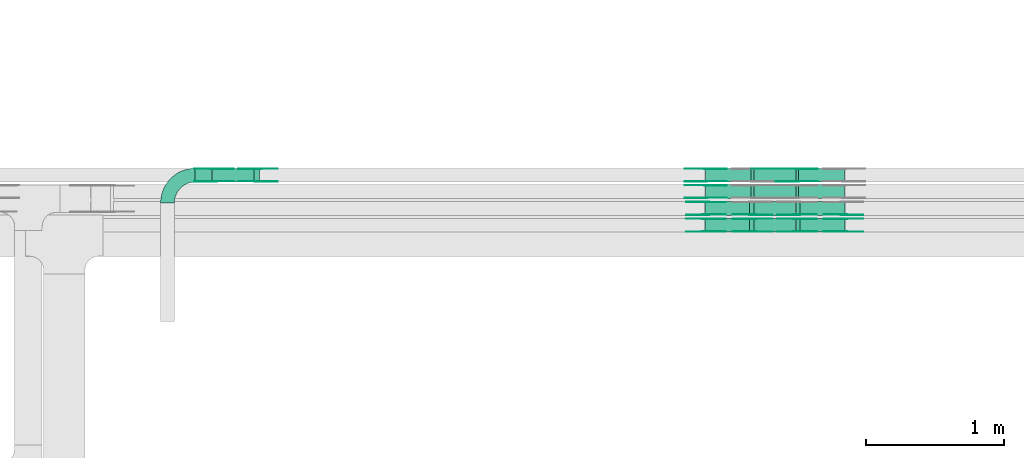
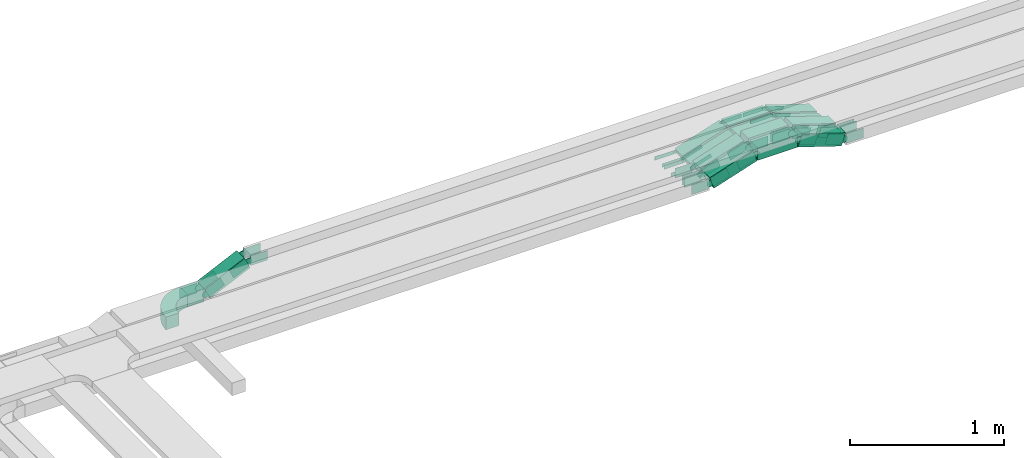
# One storey, part 8 of 19: 48 flow fittings, 14 flow segments.
"""IFC2X3 building model written with IfcOpenShell, lengths in millimetres."""

from ifc_helpers import new_model, entity, si_unit, converted_unit, derived_unit, direction, frame, frame_2d, origin, origin_2d_with_axis, place, context, subcontext, project, spatial, polyline, circle_curve, parameter, trimmed, segment, composite_curve, rectangle, outline, extrude, source, transform, mapped, material, type_object, type_shapes, element, save


model = new_model("IFC2X3")

# Units and contexts
model_context = context("Model", 3, precision=0.01, world=origin(), true_north=direction((6.12303176911189e-17, 1.0)))
body_context = subcontext(model_context, "Body", "Model", "MODEL_VIEW")
ifc_project = project(units=[si_unit("LENGTHUNIT", "METRE", prefix="MILLI"), si_unit("AREAUNIT", "SQUARE_METRE"), si_unit("VOLUMEUNIT", "CUBIC_METRE"), converted_unit("PLANEANGLEUNIT", "DEGREE", entity("IfcRatioMeasure", 0.0174532925199433), si_unit("PLANEANGLEUNIT", "RADIAN"), dimensions=[0, 0, 0, 0, 0, 0, 0]), si_unit("MASSUNIT", "GRAM", prefix="KILO"), derived_unit("MASSDENSITYUNIT", [(si_unit("MASSUNIT", "GRAM", prefix="KILO"), 1), (si_unit("LENGTHUNIT", "METRE"), -3)]), derived_unit("MOMENTOFINERTIAUNIT", [(si_unit("LENGTHUNIT", "METRE"), 4)]), si_unit("TIMEUNIT", "SECOND"), si_unit("FREQUENCYUNIT", "HERTZ"), si_unit("THERMODYNAMICTEMPERATUREUNIT", "DEGREE_CELSIUS"), derived_unit("THERMALTRANSMITTANCEUNIT", [(si_unit("MASSUNIT", "GRAM", prefix="KILO"), 1), (si_unit("THERMODYNAMICTEMPERATUREUNIT", "KELVIN"), -1), (si_unit("TIMEUNIT", "SECOND"), -3)]), derived_unit("VOLUMETRICFLOWRATEUNIT", [(si_unit("LENGTHUNIT", "METRE"), 3), (si_unit("TIMEUNIT", "SECOND"), -1)]), derived_unit("MASSFLOWRATEUNIT", [(si_unit("MASSUNIT", "GRAM", prefix="KILO"), 1), (si_unit("TIMEUNIT", "SECOND"), -1)]), derived_unit("ROTATIONALFREQUENCYUNIT", [(si_unit("TIMEUNIT", "SECOND"), -1)]), si_unit("ELECTRICCURRENTUNIT", "AMPERE"), si_unit("ELECTRICVOLTAGEUNIT", "VOLT"), si_unit("POWERUNIT", "WATT"), si_unit("FORCEUNIT", "NEWTON", prefix="KILO"), si_unit("ILLUMINANCEUNIT", "LUX"), si_unit("LUMINOUSFLUXUNIT", "LUMEN"), si_unit("LUMINOUSINTENSITYUNIT", "CANDELA"), derived_unit("USERDEFINED", [(si_unit("MASSUNIT", "GRAM", prefix="KILO"), -1), (si_unit("LENGTHUNIT", "METRE"), -2), (si_unit("TIMEUNIT", "SECOND"), 3), (si_unit("LUMINOUSFLUXUNIT", "LUMEN"), 1)]), derived_unit("LINEARVELOCITYUNIT", [(si_unit("LENGTHUNIT", "METRE"), 1), (si_unit("TIMEUNIT", "SECOND"), -1)]), si_unit("PRESSUREUNIT", "PASCAL"), derived_unit("USERDEFINED", [(si_unit("LENGTHUNIT", "METRE"), -2), (si_unit("MASSUNIT", "GRAM", prefix="KILO"), 1), (si_unit("TIMEUNIT", "SECOND"), -2)]), derived_unit("LINEARFORCEUNIT", [(si_unit("MASSUNIT", "GRAM", prefix="KILO"), 1), (si_unit("LENGTHUNIT", "METRE"), 1), (si_unit("TIMEUNIT", "SECOND"), -2), (si_unit("LENGTHUNIT", "METRE"), -1)]), derived_unit("PLANARFORCEUNIT", [(si_unit("MASSUNIT", "GRAM", prefix="KILO"), 1), (si_unit("LENGTHUNIT", "METRE"), 1), (si_unit("TIMEUNIT", "SECOND"), -2), (si_unit("LENGTHUNIT", "METRE"), -2)])], contexts=[model_context])

# Site, building, storey
site_placement = place(None, frame((0.0, -0.00077364408347762, 0.0)))
site = spatial("IfcSite", under=ifc_project, at=site_placement, CompositionType="ELEMENT")
building_placement = place(site_placement, origin())
building = spatial("IfcBuilding", under=site, at=building_placement, CompositionType="ELEMENT")
storey_placement = place(building_placement, frame((0.0, 0.0, 12000.0)))
storey = spatial("IfcBuildingStorey", under=building, at=storey_placement, CompositionType="ELEMENT", Elevation=12000.0)

# Flow segments
cable_carrier_segment_type = type_object("IfcCableCarrierSegmentType", PredefinedType="CABLETRAYSEGMENT")
flow_segment_1_placement = place(storey_placement, frame((19454.0361878455, 14792.4967897, 2660.16660841013)))
element("IfcFlowSegment", 1, at=flow_segment_1_placement, inside=storey, type_object=cable_carrier_segment_type, context=body_context, shape_type="SweptSolid", body=[
    extrude(rectangle(XDim=100.000000000002, YDim=99.9999999999989, at=origin_2d_with_axis()), frame((21.1309130872599, 50.0, 45.315389351734), z_axis=(0.906307787034617, 0.0, 0.422618261745059), x_axis=(-0.422618261745059, 0.0, 0.906307787034617)), (0.0, 0.0, 1.0), 328.987213903568),
])
flow_segment_2_placement = place(storey_placement, frame((19327.5152668448, 14792.4967897, 2650.0)))
element("IfcFlowSegment", 2, at=flow_segment_2_placement, inside=storey, type_object=cable_carrier_segment_type, context=body_context, shape_type="SweptSolid", body=[
    extrude(rectangle(XDim=122.924140166767, YDim=99.9999999999989, at=frame_2d((-1.08357767203415e-12, 0.0), x_axis=(1.0, 0.0))), frame((61.4620700833843, 50.0, 0.0), z_axis=(0.0, 0.0, 1.0), x_axis=(-1.0, 0.0, 0.0)), (0.0, 0.0, 1.0), 99.9999999999989),
])
flow_segment_3_placement = place(storey_placement, frame((23686.3473335923, 14792.4967897, 2502.95196511442)))
element("IfcFlowSegment", 3, at=flow_segment_3_placement, inside=storey, type_object=cable_carrier_segment_type, context=body_context, shape_type="SweptSolid", body=[
    extrude(rectangle(XDim=50.0000000000005, YDim=99.9999999999989, at=origin_2d_with_axis()), frame((7.72542485937545, 50.0, 131.565774838742), z_axis=(0.951056516295132, 0.0, -0.309016994375015), x_axis=(0.309016994375015, 0.0, 0.951056516295132)), (0.0, 0.0, 1.0), 348.813702461178),
])
flow_segment_4_placement = place(storey_placement, frame((23376.396793967, 14792.4967897, 2611.24611797497)))
element("IfcFlowSegment", 4, at=flow_segment_4_placement, inside=storey, type_object=cable_carrier_segment_type, context=body_context, shape_type="SweptSolid", body=[
    extrude(rectangle(XDim=306.763415131531, YDim=99.9999999999989, at=origin_2d_with_axis()), frame((153.381707565766, 50.0, 0.0), z_axis=(0.0, 0.0, 1.0), x_axis=(-1.0, 0.0, 0.0)), (0.0, 0.0, 1.0), 50.0000000000016),
])
flow_segment_5_placement = place(storey_placement, frame((23026.0172750557, 14792.4967897, 2502.95196511442)))
element("IfcFlowSegment", 5, at=flow_segment_5_placement, inside=storey, type_object=cable_carrier_segment_type, context=body_context, shape_type="SweptSolid", body=[
    extrude(rectangle(XDim=49.9999999999991, YDim=99.9999999999989, at=frame_2d((0.0, 6.69686528453894e-13), x_axis=(0.0, 1.0))), frame((7.72542485937978, 50.0, 23.7764129073785), z_axis=(0.951056516295132, 0.0, 0.309016994375015), x_axis=(0.0, 1.0, 0.0)), (0.0, 0.0, 1.0), 348.813702461196),
])
flow_segment_6_placement = place(storey_placement, frame((23686.3473335923, 14673.6298749259, 2502.95196511437)))
element("IfcFlowSegment", 6, at=flow_segment_6_placement, inside=storey, type_object=cable_carrier_segment_type, context=body_context, shape_type="SweptSolid", body=[
    extrude(rectangle(XDim=50.0000000000005, YDim=99.9999999999989, at=frame_2d((0.0, -2.16715534406831e-12), x_axis=(1.0, 0.0))), frame((7.72542485937545, 50.0, 131.565774838805), z_axis=(0.951056516295132, 0.0, -0.309016994375015), x_axis=(0.309016994375015, 0.0, 0.951056516295132)), (0.0, 0.0, 1.0), 348.813702461366),
])
flow_segment_7_placement = place(storey_placement, frame((23376.396793967, 14673.6298749258, 2611.24611797498)))
element("IfcFlowSegment", 7, at=flow_segment_7_placement, inside=storey, type_object=cable_carrier_segment_type, context=body_context, shape_type="SweptSolid", body=[
    extrude(rectangle(XDim=306.763415131523, YDim=99.9999999999989, at=frame_2d((0.0, -2.16715534406831e-12), x_axis=(1.0, 0.0))), frame((153.381707565761, 50.0, 0.0), z_axis=(0.0, 0.0, 1.0), x_axis=(-1.0, 0.0, 0.0)), (0.0, 0.0, 1.0), 50.0000000000016),
])
flow_segment_8_placement = place(storey_placement, frame((23026.0172750555, 14673.6298749258, 2502.95196511436)))
element("IfcFlowSegment", 8, at=flow_segment_8_placement, inside=storey, type_object=cable_carrier_segment_type, context=body_context, shape_type="SweptSolid", body=[
    extrude(rectangle(XDim=50.0000000000005, YDim=99.9999999999989, at=frame_2d((-2.16715534406831e-12, 0.0), x_axis=(0.0, 1.0))), frame((7.72542485937545, 50.0, 23.7764129073785), z_axis=(0.951056516295132, 0.0, 0.309016994375015), x_axis=(0.0, 1.0, 0.0)), (0.0, 0.0, 1.0), 348.813702461398),
])
flow_segment_9_placement = place(storey_placement, frame((23681.3118179754, 14551.4220205216, 2505.39913929964)))
element("IfcFlowSegment", 9, at=flow_segment_9_placement, inside=storey, type_object=cable_carrier_segment_type, context=body_context, shape_type="SweptSolid", body=[
    extrude(rectangle(XDim=99.9999999999988, YDim=99.9999999999989, at=frame_2d((-1.02318153949454e-12, 0.0), x_axis=(1.0, 0.0))), frame((15.4508497187509, 50.0, 152.895013560995), z_axis=(0.95105651629513, 0.0, -0.309016994375022), x_axis=(0.309016994375022, 0.0, 0.95105651629513)), (0.0, 0.0, 1.0), 340.894480445313),
])
flow_segment_10_placement = place(storey_placement, frame((23379.2805003663, 14551.4220205216, 2611.24611797507)))
element("IfcFlowSegment", 10, at=flow_segment_10_placement, inside=storey, type_object=cable_carrier_segment_type, context=body_context, shape_type="SweptSolid", body=[
    extrude(rectangle(XDim=298.844193115582, YDim=99.9999999999989, at=origin_2d_with_axis()), frame((149.422096557791, 50.0, 0.0), z_axis=(0.0, 0.0, 1.0), x_axis=(-1.0, 0.0, 0.0)), (0.0, 0.0, 1.0), 99.9999999999989),
])
flow_segment_11_placement = place(storey_placement, frame((23020.9916979481, 14551.4220205216, 2505.4023685171)))
element("IfcFlowSegment", 11, at=flow_segment_11_placement, inside=storey, type_object=cable_carrier_segment_type, context=body_context, shape_type="SweptSolid", body=[
    extrude(rectangle(XDim=100.000000000001, YDim=99.9999999999989, at=frame_2d((0.0, 0.0), x_axis=(0.0, 1.0))), frame((15.4508497187509, 50.0, 47.552825814757), z_axis=(0.951056516295132, 0.0, 0.309016994375015), x_axis=(0.0, 1.0, 0.0)), (0.0, 0.0, 1.0), 340.884030478122),
])
flow_segment_12_placement = place(storey_placement, frame((23681.3118179754, 14429.9939090692, 2505.39913929964)))
element("IfcFlowSegment", 12, at=flow_segment_12_placement, inside=storey, type_object=cable_carrier_segment_type, context=body_context, shape_type="SweptSolid", body=[
    extrude(rectangle(XDim=100.000000000001, YDim=99.9999999999989, at=origin_2d_with_axis()), frame((15.4508497187509, 50.0, 152.895013560993), z_axis=(0.951056516295132, 0.0, -0.309016994375015), x_axis=(0.309016994375015, 0.0, 0.951056516295132)), (0.0, 0.0, 1.0), 340.894480445308),
])
flow_segment_13_placement = place(storey_placement, frame((23379.2805003663, 14429.9939090692, 2611.24611797507)))
element("IfcFlowSegment", 13, at=flow_segment_13_placement, inside=storey, type_object=cable_carrier_segment_type, context=body_context, shape_type="SweptSolid", body=[
    extrude(rectangle(XDim=298.844193115587, YDim=99.9999999999989, at=frame_2d((2.1600499167107e-12, 0.0), x_axis=(1.0, 0.0))), frame((149.422096557791, 50.0, 0.0), z_axis=(0.0, 0.0, 1.0), x_axis=(-1.0, 0.0, 0.0)), (0.0, 0.0, 1.0), 99.9999999999989),
])
flow_segment_14_placement = place(storey_placement, frame((23021.0069797313, 14429.9939090692, 2505.40733386946)))
element("IfcFlowSegment", 14, at=flow_segment_14_placement, inside=storey, type_object=cable_carrier_segment_type, context=body_context, shape_type="SweptSolid", body=[
    extrude(rectangle(XDim=100.000000000001, YDim=99.9999999999989, at=frame_2d((0.0, 0.0), x_axis=(0.0, 1.0))), frame((15.4508497187509, 50.0, 47.5528258147548), z_axis=(0.951056516295132, 0.0, 0.309016994375015), x_axis=(0.0, 1.0, 0.0)), (0.0, 0.0, 1.0), 340.867962260358),
])

# Flow fittings
ifc_material_1 = material(Name="G")
cable_carrier_fitting_type_1 = type_object("IfcCableCarrierFittingType", PredefinedType="NOTDEFINED", material=ifc_material_1)
shared_shape_1 = source(origin(), body_context, "Body", "SweptSolid", [
    extrude(outline(composite_curve([segment(trimmed(circle_curve(frame_2d((-44.5901162790698, 0.0), x_axis=(1.0, 0.0)), 12.5), [parameter(90.0000000000007)], [parameter(270.0)], True, "PARAMETER"), True, "CONTINUOUS"), segment(polyline([(-44.5901162790697, -12.5), (-33.0901162790698, -12.5)]), True, "CONTINUOUS"), segment(polyline([(-33.0901162790698, -12.5), (-31.2296511627907, -14.5)]), True, "CONTINUOUS"), segment(polyline([(-31.2296511627907, -14.5), (108.90988372093, -14.5)]), True, "CONTINUOUS"), segment(polyline([(108.90988372093, -14.5), (108.90988372093, 14.5)]), True, "CONTINUOUS"), segment(polyline([(108.90988372093, 14.5), (-31.2296511627907, 14.5)]), True, "CONTINUOUS"), segment(polyline([(-31.2296511627907, 14.5), (-33.0901162790698, 12.5)]), True, "CONTINUOUS"), segment(polyline([(-33.0901162790698, 12.5), (-44.5901162790699, 12.5)]), True, "CONTINUOUS")], self_intersect=False)), frame((44.5901162790698, 0.0, 0.0), z_axis=(0.0, 0.0, -1.0), x_axis=(1.0, 0.0, 0.0)), (0.0, 0.0, -1.0), 2.0),
])
type_shapes(cable_carrier_fitting_type_1, [shared_shape_1])
for number, where, z_axis, x_axis in (
    (15, (23688.753357868, 14797.0367896899, 2636.246117975), (0.0, -1.0, 0.0), (-1.0, 0.0, 0.0)),
    (16, (23370.8036451976, 14887.9567897102, 2636.246117975), (0.0, 1.0, 0.0), (1.0, 0.0, 0.0)),
    (17, (23028.4232993313, 14887.9567897102, 2525.0), (0.0, 1.0, 0.0), (-1.0, 0.0, 0.0)),
    (18, (23028.4232993311, 14769.089874936, 2525.0), (0.0, 1.0, 0.0), (-1.0, 0.0, 0.0)),
):
    element("IfcFlowFitting", number, at=place(storey_placement, frame(where, z_axis=z_axis, x_axis=x_axis)), inside=storey, type_object=cable_carrier_fitting_type_1, material=ifc_material_1, context=body_context, shape_type="MappedRepresentation", body=[
        mapped(shared_shape_1, transform((0.0, 0.0, 0.0), scale=1.0)),
    ])
cable_carrier_fitting_type_2 = type_object("IfcCableCarrierFittingType", PredefinedType="NOTDEFINED", material=ifc_material_1)
shared_shape_2 = source(origin(), body_context, "Body", "SweptSolid", [
    extrude(outline(composite_curve([segment(trimmed(circle_curve(frame_2d((-44.5901162790697, 0.0), x_axis=(1.0, 0.0)), 12.5), [parameter(90.0000000000007)], [parameter(270.0)], True, "PARAMETER"), True, "CONTINUOUS"), segment(polyline([(-44.5901162790697, -12.5), (-33.0901162790697, -12.5)]), True, "CONTINUOUS"), segment(polyline([(-33.0901162790697, -12.5), (-31.2296511627907, -14.5)]), True, "CONTINUOUS"), segment(polyline([(-31.2296511627907, -14.5), (108.90988372093, -14.5)]), True, "CONTINUOUS"), segment(polyline([(108.90988372093, -14.5), (108.90988372093, 14.5)]), True, "CONTINUOUS"), segment(polyline([(108.90988372093, 14.5), (-31.2296511627907, 14.5)]), True, "CONTINUOUS"), segment(polyline([(-31.2296511627907, 14.5), (-33.0901162790698, 12.5)]), True, "CONTINUOUS"), segment(polyline([(-33.0901162790698, 12.5), (-44.5901162790699, 12.5)]), True, "CONTINUOUS")], self_intersect=False)), frame((44.5901162790697, 0.0, 0.0)), (0.0, 0.0, 1.0), 2.0),
])
type_shapes(cable_carrier_fitting_type_2, [shared_shape_2])
for number, where, z_axis, x_axis in (
    (19, (23688.753357868, 14887.9567897102, 2636.246117975), (0.0, 1.0, 0.0), (-1.0, 0.0, 0.0)),
    (20, (23028.4232993313, 14797.0367896899, 2525.0), (0.0, -1.0, 0.0), (-1.0, 0.0, 0.0)),
    (21, (23028.4232993311, 14678.1698749157, 2525.0), (0.0, -1.0, 0.0), (-1.0, 0.0, 0.0)),
):
    element("IfcFlowFitting", number, at=place(storey_placement, frame(where, z_axis=z_axis, x_axis=x_axis)), inside=storey, type_object=cable_carrier_fitting_type_2, material=ifc_material_1, context=body_context, shape_type="MappedRepresentation", body=[
        mapped(shared_shape_2, transform((0.0, 0.0, 0.0), scale=1.0)),
    ])
cable_carrier_fitting_type_3 = type_object("IfcCableCarrierFittingType", PredefinedType="NOTDEFINED", material=ifc_material_1)
shared_shape_3 = source(origin(), body_context, "Body", "SweptSolid", [
    extrude(outline(composite_curve([segment(trimmed(circle_curve(frame_2d((-44.5901162790698, 0.0), x_axis=(1.0, 0.0)), 12.5), [parameter(90.0000000000007)], [parameter(270.0)], True, "PARAMETER"), True, "CONTINUOUS"), segment(polyline([(-44.5901162790697, -12.5), (-33.0901162790698, -12.5)]), True, "CONTINUOUS"), segment(polyline([(-33.0901162790698, -12.5), (-31.2296511627907, -14.5)]), True, "CONTINUOUS"), segment(polyline([(-31.2296511627907, -14.5), (108.90988372093, -14.5)]), True, "CONTINUOUS"), segment(polyline([(108.90988372093, -14.5), (108.90988372093, 14.5)]), True, "CONTINUOUS"), segment(polyline([(108.90988372093, 14.5), (-31.2296511627907, 14.5)]), True, "CONTINUOUS"), segment(polyline([(-31.2296511627907, 14.5), (-33.0901162790698, 12.5)]), True, "CONTINUOUS"), segment(polyline([(-33.0901162790698, 12.5), (-44.5901162790699, 12.5)]), True, "CONTINUOUS")], self_intersect=False)), frame((44.5901162790698, 0.0, 0.0), z_axis=(0.0, 0.0, -1.0), x_axis=(1.0, 0.0, 0.0)), (0.0, 0.0, -1.0), 2.0),
])
type_shapes(cable_carrier_fitting_type_3, [shared_shape_3])
for number, where, z_axis, x_axis in (
    (22, (23688.7533578679, 14885.9567897102, 2636.246117975), (0.0, 1.0, 0.0), (0.951056516295156, 0.0, -0.309016994374939)),
    (23, (23028.4232993313, 14799.0367896899, 2525.0), (0.0, -1.0, 0.0), (0.951056516295161, 0.0, 0.309016994374923)),
    (24, (23028.4232993311, 14680.1698749157, 2525.0), (0.0, -1.0, 0.0), (0.95105651629516, 0.0, 0.309016994374927)),
):
    element("IfcFlowFitting", number, at=place(storey_placement, frame(where, z_axis=z_axis, x_axis=x_axis)), inside=storey, type_object=cable_carrier_fitting_type_3, material=ifc_material_1, context=body_context, shape_type="MappedRepresentation", body=[
        mapped(shared_shape_3, transform((0.0, 0.0, 0.0), scale=1.0)),
    ])
cable_carrier_fitting_type_4 = type_object("IfcCableCarrierFittingType", PredefinedType="NOTDEFINED", material=ifc_material_1)
shared_shape_4 = source(origin(), body_context, "Body", "SweptSolid", [
    extrude(outline(composite_curve([segment(trimmed(circle_curve(frame_2d((-44.5901162790697, 0.0), x_axis=(1.0, 0.0)), 12.5), [parameter(90.0000000000007)], [parameter(270.0)], True, "PARAMETER"), True, "CONTINUOUS"), segment(polyline([(-44.5901162790697, -12.5), (-33.0901162790697, -12.5)]), True, "CONTINUOUS"), segment(polyline([(-33.0901162790697, -12.5), (-31.2296511627907, -14.5)]), True, "CONTINUOUS"), segment(polyline([(-31.2296511627907, -14.5), (108.90988372093, -14.5)]), True, "CONTINUOUS"), segment(polyline([(108.90988372093, -14.5), (108.90988372093, 14.5)]), True, "CONTINUOUS"), segment(polyline([(108.90988372093, 14.5), (-31.2296511627907, 14.5)]), True, "CONTINUOUS"), segment(polyline([(-31.2296511627907, 14.5), (-33.0901162790698, 12.5)]), True, "CONTINUOUS"), segment(polyline([(-33.0901162790698, 12.5), (-44.5901162790699, 12.5)]), True, "CONTINUOUS")], self_intersect=False)), frame((44.5901162790697, 0.0, 0.0)), (0.0, 0.0, 1.0), 2.0),
])
type_shapes(cable_carrier_fitting_type_4, [shared_shape_4])
for number, where, z_axis, x_axis in (
    (25, (23688.7533578679, 14799.0367896899, 2636.246117975), (0.0, -1.0, 0.0), (0.951056516295156, 0.0, -0.309016994374939)),
    (26, (23028.4232993313, 14885.9567897102, 2525.0), (0.0, 1.0, 0.0), (0.951056516295161, 0.0, 0.309016994374923)),
    (27, (23028.4232993311, 14767.089874936, 2525.0), (0.0, 1.0, 0.0), (0.95105651629516, 0.0, 0.309016994374927)),
):
    element("IfcFlowFitting", number, at=place(storey_placement, frame(where, z_axis=z_axis, x_axis=x_axis)), inside=storey, type_object=cable_carrier_fitting_type_4, material=ifc_material_1, context=body_context, shape_type="MappedRepresentation", body=[
        mapped(shared_shape_4, transform((0.0, 0.0, 0.0), scale=1.0)),
    ])
cable_carrier_fitting_type_5 = type_object("IfcCableCarrierFittingType", PredefinedType="NOTDEFINED", material=ifc_material_1)
shared_shape_5 = source(origin(), body_context, "Body", "SweptSolid", [
    extrude(outline(composite_curve([segment(trimmed(circle_curve(frame_2d((-41.4651162790697, 0.0), x_axis=(1.0, 0.0)), 25.0), [parameter(90.0000000000007)], [parameter(270.0)], True, "PARAMETER"), True, "CONTINUOUS"), segment(polyline([(-41.4651162790697, -25.0), (-29.9651162790697, -25.0)]), True, "CONTINUOUS"), segment(polyline([(-29.9651162790697, -25.0), (-28.1046511627907, -38.5)]), True, "CONTINUOUS"), segment(polyline([(-28.1046511627907, -38.5), (99.5348837209303, -38.5)]), True, "CONTINUOUS"), segment(polyline([(99.5348837209303, -38.5), (99.5348837209303, 38.5)]), True, "CONTINUOUS"), segment(polyline([(99.5348837209303, 38.5), (-28.1046511627907, 38.5)]), True, "CONTINUOUS"), segment(polyline([(-28.1046511627907, 38.5), (-29.9651162790697, 25.0)]), True, "CONTINUOUS"), segment(polyline([(-29.9651162790697, 25.0), (-41.46511627907, 25.0)]), True, "CONTINUOUS")], self_intersect=False)), frame((41.4651162790697, 0.0, 0.0), z_axis=(0.0, 0.0, -1.0), x_axis=(1.0, 0.0, 0.0)), (0.0, 0.0, -1.0), 2.0),
])
type_shapes(cable_carrier_fitting_type_5, [shared_shape_5])
for number, where, z_axis, x_axis in (
    (28, (19463.4109187944, 14887.9567897102, 2700.0), (0.0, 1.0, 0.0), (-1.0, 0.0, 0.0)),
    (29, (19785.0869568668, 14887.9567897102, 2850.0), (0.0, 1.0, 0.0), (1.0, 0.0, 0.0)),
    (30, (23687.6774532593, 14555.9620205114, 2661.24611797505), (0.0, -1.0, 0.0), (-1.0, 0.0, 0.0)),
    (31, (23027.3473947225, 14646.8820205317, 2550.0), (0.0, 1.0, 0.0), (-0.999999928726835, 0.0, 0.000377553074818682)),
    (32, (24030.0577991256, 14555.9620205114, 2550.0), (0.0, -1.0, 0.0), (1.0, 0.0, 0.0)),
    (33, (23687.6774532593, 14434.5339090591, 2661.24611797505), (0.0, -1.0, 0.0), (-1.0, 0.0, 0.0)),
    (34, (23369.7277405889, 14525.4539090794, 2661.24611797505), (0.0, 1.0, 0.0), (1.0, 0.0, 0.0)),
    (35, (23027.3726557256, 14525.4539090794, 2550.00820779743), (0.0, 1.0, 0.0), (-1.0, 0.0, -1.54659777390487e-06)),
    (36, (24030.0577991256, 14434.5339090591, 2550.0), (0.0, -1.0, 0.0), (1.0, 0.0, 0.0)),
):
    element("IfcFlowFitting", number, at=place(storey_placement, frame(where, z_axis=z_axis, x_axis=x_axis)), inside=storey, type_object=cable_carrier_fitting_type_5, material=ifc_material_1, context=body_context, shape_type="MappedRepresentation", body=[
        mapped(shared_shape_5, transform((0.0, 0.0, 0.0), scale=1.0)),
    ])
cable_carrier_fitting_type_6 = type_object("IfcCableCarrierFittingType", PredefinedType="NOTDEFINED", material=ifc_material_1)
shared_shape_6 = source(origin(), body_context, "Body", "SweptSolid", [
    extrude(outline(composite_curve([segment(trimmed(circle_curve(frame_2d((-41.4651162790697, 0.0), x_axis=(1.0, 0.0)), 25.0), [parameter(90.0000000000007)], [parameter(270.0)], True, "PARAMETER"), True, "CONTINUOUS"), segment(polyline([(-41.4651162790697, -25.0), (-29.9651162790697, -25.0)]), True, "CONTINUOUS"), segment(polyline([(-29.9651162790697, -25.0), (-28.1046511627907, -38.5)]), True, "CONTINUOUS"), segment(polyline([(-28.1046511627907, -38.5), (99.5348837209303, -38.5)]), True, "CONTINUOUS"), segment(polyline([(99.5348837209303, -38.5), (99.5348837209303, 38.5)]), True, "CONTINUOUS"), segment(polyline([(99.5348837209303, 38.5), (-28.1046511627907, 38.5)]), True, "CONTINUOUS"), segment(polyline([(-28.1046511627907, 38.5), (-29.9651162790697, 25.0)]), True, "CONTINUOUS"), segment(polyline([(-29.9651162790697, 25.0), (-41.46511627907, 25.0)]), True, "CONTINUOUS")], self_intersect=False)), frame((41.4651162790697, 0.0, 0.0)), (0.0, 0.0, 1.0), 2.0),
])
type_shapes(cable_carrier_fitting_type_6, [shared_shape_6])
for number, where, z_axis, x_axis in (
    (37, (19463.4109187944, 14797.0367896899, 2700.0), (0.0, -1.0, 0.0), (-1.0, 0.0, 0.0)),
    (38, (19785.0869568668, 14797.0367896898, 2850.0), (0.0, -1.0, 0.0), (1.0, 0.0, 0.0)),
    (39, (23369.7277405889, 14555.9620205114, 2661.24611797505), (0.0, -1.0, 0.0), (1.0, 0.0, 0.0)),
    (40, (23027.3473947225, 14555.9620205114, 2550.0), (0.0, -1.0, 0.0), (-0.999999928726835, 0.0, 0.000377553074818682)),
    (41, (23687.6774532593, 14525.4539090794, 2661.24611797505), (0.0, 1.0, 0.0), (-1.0, 0.0, 0.0)),
    (42, (23369.7277405889, 14434.5339090591, 2661.24611797505), (0.0, -1.0, 0.0), (1.0, 0.0, 0.0)),
    (43, (23027.3726557256, 14434.5339090591, 2550.00820779743), (0.0, -1.0, 0.0), (-1.0, 0.0, -1.54659777390487e-06)),
    (44, (24030.0577991256, 14525.4539090794, 2550.0), (0.0, 1.0, 0.0), (1.0, 0.0, 0.0)),
):
    element("IfcFlowFitting", number, at=place(storey_placement, frame(where, z_axis=z_axis, x_axis=x_axis)), inside=storey, type_object=cable_carrier_fitting_type_6, material=ifc_material_1, context=body_context, shape_type="MappedRepresentation", body=[
        mapped(shared_shape_6, transform((0.0, 0.0, 0.0), scale=1.0)),
    ])
cable_carrier_fitting_type_7 = type_object("IfcCableCarrierFittingType", PredefinedType="NOTDEFINED", material=ifc_material_1)
shared_shape_7 = source(origin(), body_context, "Body", "SweptSolid", [
    extrude(outline(composite_curve([segment(trimmed(circle_curve(frame_2d((-41.4651162790697, 0.0), x_axis=(1.0, 0.0)), 25.0), [parameter(90.0000000000007)], [parameter(270.0)], True, "PARAMETER"), True, "CONTINUOUS"), segment(polyline([(-41.4651162790697, -25.0), (-29.9651162790697, -25.0)]), True, "CONTINUOUS"), segment(polyline([(-29.9651162790697, -25.0), (-28.1046511627907, -38.5)]), True, "CONTINUOUS"), segment(polyline([(-28.1046511627907, -38.5), (99.5348837209303, -38.5)]), True, "CONTINUOUS"), segment(polyline([(99.5348837209303, -38.5), (99.5348837209303, 38.5)]), True, "CONTINUOUS"), segment(polyline([(99.5348837209303, 38.5), (-28.1046511627907, 38.5)]), True, "CONTINUOUS"), segment(polyline([(-28.1046511627907, 38.5), (-29.9651162790697, 25.0)]), True, "CONTINUOUS"), segment(polyline([(-29.9651162790697, 25.0), (-41.46511627907, 25.0)]), True, "CONTINUOUS")], self_intersect=False)), frame((41.4651162790697, 0.0, 0.0), z_axis=(0.0, 0.0, -1.0), x_axis=(1.0, 0.0, 0.0)), (0.0, 0.0, -1.0), 2.0),
])
type_shapes(cable_carrier_fitting_type_7, [shared_shape_7])
for number, where, z_axis, x_axis in (
    (45, (19463.4109187944, 14799.0367896899, 2700.0), (0.0, -1.0, 0.0), (0.90630778703479, 0.0, 0.422618261744688)),
    (46, (19785.0869568668, 14799.0367896898, 2850.0), (0.0, -1.0, 0.0), (-0.906307787034621, 0.0, -0.422618261745051)),
    (47, (23369.7277405889, 14557.9620205114, 2661.24611797505), (0.0, -1.0, 0.0), (-0.951056516295156, 0.0, -0.309016994374939)),
    (48, (23027.3473947225, 14557.9620205114, 2550.0), (0.0, -1.0, 0.0), (0.951056516295155, 0.0, 0.309016994374943)),
    (49, (23687.6774532593, 14523.4539090794, 2661.24611797505), (0.0, 1.0, 0.0), (0.951056516295156, 0.0, -0.309016994374939)),
    (50, (23369.7277405889, 14436.5339090591, 2661.24611797505), (0.0, -1.0, 0.0), (-0.951056516295156, 0.0, -0.309016994374939)),
    (51, (23027.3726557256, 14436.5339090591, 2550.00820779743), (0.0, -1.0, 0.0), (0.951056516295154, 0.0, 0.309016994374947)),
    (52, (24030.0577991256, 14523.4539090794, 2550.0), (0.0, 1.0, 0.0), (-0.951056516295155, 0.0, 0.309016994374944)),
):
    element("IfcFlowFitting", number, at=place(storey_placement, frame(where, z_axis=z_axis, x_axis=x_axis)), inside=storey, type_object=cable_carrier_fitting_type_7, material=ifc_material_1, context=body_context, shape_type="MappedRepresentation", body=[
        mapped(shared_shape_7, transform((0.0, 0.0, 0.0), scale=1.0)),
    ])
cable_carrier_fitting_type_8 = type_object("IfcCableCarrierFittingType", PredefinedType="NOTDEFINED", material=ifc_material_1)
shared_shape_8 = source(origin(), body_context, "Body", "SweptSolid", [
    extrude(outline(composite_curve([segment(trimmed(circle_curve(frame_2d((-41.4651162790697, 0.0), x_axis=(1.0, 0.0)), 25.0), [parameter(90.0000000000007)], [parameter(270.0)], True, "PARAMETER"), True, "CONTINUOUS"), segment(polyline([(-41.4651162790697, -25.0), (-29.9651162790697, -25.0)]), True, "CONTINUOUS"), segment(polyline([(-29.9651162790697, -25.0), (-28.1046511627907, -38.5)]), True, "CONTINUOUS"), segment(polyline([(-28.1046511627907, -38.5), (99.5348837209303, -38.5)]), True, "CONTINUOUS"), segment(polyline([(99.5348837209303, -38.5), (99.5348837209303, 38.5)]), True, "CONTINUOUS"), segment(polyline([(99.5348837209303, 38.5), (-28.1046511627907, 38.5)]), True, "CONTINUOUS"), segment(polyline([(-28.1046511627907, 38.5), (-29.9651162790697, 25.0)]), True, "CONTINUOUS"), segment(polyline([(-29.9651162790697, 25.0), (-41.46511627907, 25.0)]), True, "CONTINUOUS")], self_intersect=False)), frame((41.4651162790697, 0.0, 0.0)), (0.0, 0.0, 1.0), 2.0),
])
type_shapes(cable_carrier_fitting_type_8, [shared_shape_8])
for number, where, z_axis, x_axis in (
    (53, (19463.4109187944, 14885.9567897102, 2700.0), (0.0, 1.0, 0.0), (0.90630778703479, 0.0, 0.422618261744688)),
    (54, (19785.0869568668, 14885.9567897102, 2850.0), (0.0, 1.0, 0.0), (-0.906307787034621, 0.0, -0.422618261745051)),
    (55, (23687.6774532593, 14557.9620205114, 2661.24611797505), (0.0, -1.0, 0.0), (0.951056516295156, 0.0, -0.309016994374939)),
    (56, (23027.3473947225, 14644.8820205317, 2550.0), (0.0, 1.0, 0.0), (0.951056516295155, 0.0, 0.309016994374943)),
    (57, (24030.0577991256, 14557.9620205114, 2550.0), (0.0, -1.0, 0.0), (-0.951056516295154, 0.0, 0.309016994374947)),
    (58, (23687.6774532593, 14436.5339090591, 2661.24611797505), (0.0, -1.0, 0.0), (0.951056516295156, 0.0, -0.309016994374939)),
    (59, (23369.7277405889, 14523.4539090794, 2661.24611797505), (0.0, 1.0, 0.0), (-0.951056516295156, 0.0, -0.309016994374939)),
    (60, (23027.3726557256, 14523.4539090794, 2550.00820779743), (0.0, 1.0, 0.0), (0.951056516295154, 0.0, 0.309016994374947)),
    (61, (24030.0577991256, 14436.5339090591, 2550.0), (0.0, -1.0, 0.0), (-0.951056516295155, 0.0, 0.309016994374944)),
):
    element("IfcFlowFitting", number, at=place(storey_placement, frame(where, z_axis=z_axis, x_axis=x_axis)), inside=storey, type_object=cable_carrier_fitting_type_8, material=ifc_material_1, context=body_context, shape_type="MappedRepresentation", body=[
        mapped(shared_shape_8, transform((0.0, 0.0, 0.0), scale=1.0)),
    ])
ifc_material_2 = material()
cable_carrier_fitting_type_9 = type_object("IfcCableCarrierFittingType", Name="470_DKC_S5_Variable Angle Elbow 0-45:-", PredefinedType="NOTDEFINED", material=ifc_material_2)
shared_shape_9 = source(origin(), body_context, "Body", "SweptSolid", [
    extrude(outline(composite_curve([segment(polyline([(-100.749999999999, -150.250000000001), (-99.7499999999981, -150.250000000001)]), True, "CONTINUOUS"), segment(trimmed(circle_curve(frame_2d((-99.7500000000006, 99.7499999999987), x_axis=(0.0, -1.0)), 250.0), [parameter(0.0)], [parameter(90.0000000000001)], True, "PARAMETER"), True, "CONTINUOUS"), segment(polyline([(150.249999999999, 99.7500000000013), (150.249999999999, 100.750000000001)]), True, "CONTINUOUS"), segment(polyline([(150.249999999999, 100.750000000001), (50.2499999999992, 100.750000000001)]), True, "CONTINUOUS"), segment(polyline([(50.2499999999992, 100.750000000001), (50.2499999999992, 99.7500000000002)]), True, "CONTINUOUS"), segment(trimmed(circle_curve(frame_2d((-99.7500000000006, 99.7499999999987), x_axis=(0.0, -1.0)), 150.0), [parameter(0.0)], [parameter(90.0000000000001)], True, "PARAMETER"), False, "CONTINUOUS"), segment(polyline([(-99.7499999999989, -50.2500000000011), (-100.75, -50.2500000000011)]), True, "CONTINUOUS"), segment(polyline([(-100.75, -50.2500000000011), (-100.749999999999, -150.250000000001)]), True, "CONTINUOUS")], self_intersect=False)), frame((-100.249999999991, 100.249999999992, -50.0)), (0.0, 0.0, 1.0), 100.0),
])
type_shapes(cable_carrier_fitting_type_9, [shared_shape_9])
flow_fitting_placement = place(storey_placement, frame((19126.5152668448, 14842.4967897, 2700.0), z_axis=(0.0, 0.0, 1.0), x_axis=(-1.0, 0.0, 0.0)))
element("IfcFlowFitting", 62, at=flow_fitting_placement, inside=storey, type_object=cable_carrier_fitting_type_9, material=ifc_material_2, Name="470_DKC_S5_Variable Angle Elbow 0-45:-", ObjectType="470_DKC_S5_Variable Angle Elbow 0-45:-", context=body_context, shape_type="MappedRepresentation", body=[
    mapped(shared_shape_9, transform((0.0, 0.0, 0.0), scale=1.0)),
])

save(model, "model.ifc")
